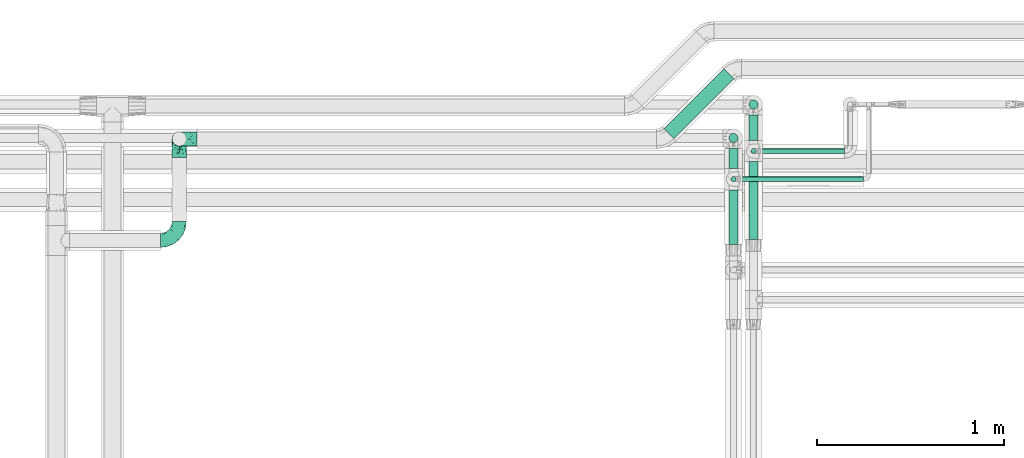
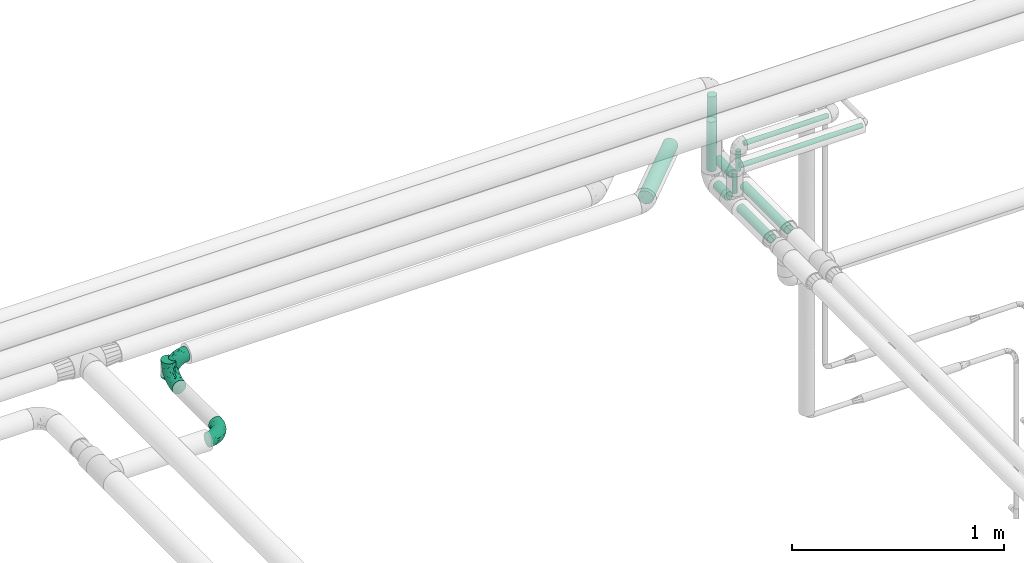
# One storey, part 654 of 827: 11 flow segments, 3 flow fittings.
"""IFC2X3 building model written with IfcOpenShell, lengths in millimetres."""

from ifc_helpers import new_model, entity, si_unit, converted_unit, derived_unit, direction, frame, origin, origin_2d_with_axis, place, context, subcontext, project, spatial, circle, extrude, faceted_brep, source, transform, mapped, material, type_object, type_shapes, element, save


model = new_model("IFC2X3")

# Units and contexts
model_context = context("Model", 3, precision=0.01, world=origin(), true_north=direction((6.12303176911189e-17, 1.0)))
body_context = subcontext(model_context, "Body", "Model", "MODEL_VIEW")
ifc_project = project(units=[si_unit("LENGTHUNIT", "METRE", prefix="MILLI"), si_unit("AREAUNIT", "SQUARE_METRE"), si_unit("VOLUMEUNIT", "CUBIC_METRE"), converted_unit("PLANEANGLEUNIT", "DEGREE", entity("IfcRatioMeasure", 0.0174532925199433), si_unit("PLANEANGLEUNIT", "RADIAN"), dimensions=[0, 0, 0, 0, 0, 0, 0]), si_unit("MASSUNIT", "GRAM", prefix="KILO"), derived_unit("MASSDENSITYUNIT", [(si_unit("MASSUNIT", "GRAM", prefix="KILO"), 1), (si_unit("LENGTHUNIT", "METRE"), -3)]), derived_unit("MOMENTOFINERTIAUNIT", [(si_unit("LENGTHUNIT", "METRE"), 4)]), si_unit("TIMEUNIT", "SECOND"), si_unit("FREQUENCYUNIT", "HERTZ"), si_unit("THERMODYNAMICTEMPERATUREUNIT", "DEGREE_CELSIUS"), derived_unit("THERMALTRANSMITTANCEUNIT", [(si_unit("MASSUNIT", "GRAM", prefix="KILO"), 1), (si_unit("THERMODYNAMICTEMPERATUREUNIT", "KELVIN"), -1), (si_unit("TIMEUNIT", "SECOND"), -3)]), derived_unit("VOLUMETRICFLOWRATEUNIT", [(si_unit("LENGTHUNIT", "METRE"), 3), (si_unit("TIMEUNIT", "SECOND"), -1)]), derived_unit("MASSFLOWRATEUNIT", [(si_unit("MASSUNIT", "GRAM", prefix="KILO"), 1), (si_unit("TIMEUNIT", "SECOND"), -1)]), derived_unit("ROTATIONALFREQUENCYUNIT", [(si_unit("TIMEUNIT", "SECOND"), -1)]), si_unit("ELECTRICCURRENTUNIT", "AMPERE"), si_unit("ELECTRICVOLTAGEUNIT", "VOLT"), si_unit("POWERUNIT", "WATT"), si_unit("FORCEUNIT", "NEWTON", prefix="KILO"), si_unit("ILLUMINANCEUNIT", "LUX"), si_unit("LUMINOUSFLUXUNIT", "LUMEN"), si_unit("LUMINOUSINTENSITYUNIT", "CANDELA"), derived_unit("USERDEFINED", [(si_unit("MASSUNIT", "GRAM", prefix="KILO"), -1), (si_unit("LENGTHUNIT", "METRE"), -2), (si_unit("TIMEUNIT", "SECOND"), 3), (si_unit("LUMINOUSFLUXUNIT", "LUMEN"), 1)]), derived_unit("LINEARVELOCITYUNIT", [(si_unit("LENGTHUNIT", "METRE"), 1), (si_unit("TIMEUNIT", "SECOND"), -1)]), si_unit("PRESSUREUNIT", "PASCAL"), derived_unit("USERDEFINED", [(si_unit("LENGTHUNIT", "METRE"), -2), (si_unit("MASSUNIT", "GRAM", prefix="KILO"), 1), (si_unit("TIMEUNIT", "SECOND"), -2)]), derived_unit("LINEARFORCEUNIT", [(si_unit("MASSUNIT", "GRAM", prefix="KILO"), 1), (si_unit("LENGTHUNIT", "METRE"), 1), (si_unit("TIMEUNIT", "SECOND"), -2), (si_unit("LENGTHUNIT", "METRE"), -1)]), derived_unit("PLANARFORCEUNIT", [(si_unit("MASSUNIT", "GRAM", prefix="KILO"), 1), (si_unit("LENGTHUNIT", "METRE"), 1), (si_unit("TIMEUNIT", "SECOND"), -2), (si_unit("LENGTHUNIT", "METRE"), -2)])], contexts=[model_context])

# Site, building, storey
site_placement = place(None, origin())
site = spatial("IfcSite", under=ifc_project, at=site_placement, CompositionType="ELEMENT")
building_placement = place(site_placement, origin())
building = spatial("IfcBuilding", under=site, at=building_placement, CompositionType="ELEMENT")
storey_placement = place(building_placement, frame((0.0, 0.0, 28200.0)))
storey = spatial("IfcBuildingStorey", under=building, at=storey_placement, Name="08", CompositionType="ELEMENT", Elevation=28200.0)

# Flow segments
pipe_segment_type = type_object("IfcPipeSegmentType", PredefinedType="NOTDEFINED")
flow_segment_1_placement = place(storey_placement, frame((40995.89, 18930.88, 2960.65)))
element("IfcFlowSegment", 1, at=flow_segment_1_placement, inside=storey, type_object=pipe_segment_type, context=body_context, shape_type="SweptSolid", body=[
    extrude(circle(Radius=37.75, at=origin_2d_with_axis()), frame((28.29, 28.29, 39.35), z_axis=(0.707106781186548, 0.707106781186548, 0.0), x_axis=(-0.707106781186548, 0.707106781186548, 0.0)), (0.0, 0.0, 1.0), 452.879995921408),
])
flow_segment_2_placement = place(storey_placement, frame((41450.62, 18393.19, 2974.4)))
element("IfcFlowSegment", 2, at=flow_segment_2_placement, inside=storey, type_object=pipe_segment_type, context=body_context, shape_type="SweptSolid", body=[
    extrude(circle(Radius=24.0, at=origin_2d_with_axis()), frame((25.6, 0.0, 25.6), z_axis=(0.0, 1.0, 0.0), x_axis=(-1.0, 0.0, 0.0)), (0.0, 0.0, 1.0), 416.031331883509),
])
flow_segment_3_placement = place(storey_placement, frame((41343.78, 18773.22, 2974.4)))
element("IfcFlowSegment", 3, at=flow_segment_3_placement, inside=storey, type_object=pipe_segment_type, context=body_context, shape_type="SweptSolid", body=[
    extrude(circle(Radius=24.0, at=origin_2d_with_axis()), frame((25.6, 0.0, 25.6), z_axis=(0.0, 1.0, 0.0), x_axis=(1.0, 0.0, 0.0)), (0.0, 0.0, 1.0), 106.243563862044),
])
flow_segment_4_placement = place(storey_placement, frame((41505.32, 18851.22, 3185.0)))
element("IfcFlowSegment", 4, at=flow_segment_4_placement, inside=storey, type_object=pipe_segment_type, context=body_context, shape_type="SweptSolid", body=[
    extrude(circle(Radius=13.4, at=origin_2d_with_axis()), frame((0.0, 15.0, 15.0), z_axis=(1.0, 0.0, 0.0), x_axis=(0.0, 1.0, 0.0)), (0.0, 0.0, 1.0), 458.985853955874),
])
flow_segment_5_placement = place(storey_placement, frame((41398.47, 18701.23, 3184.95)))
element("IfcFlowSegment", 5, at=flow_segment_5_placement, inside=storey, type_object=pipe_segment_type, context=body_context, shape_type="SweptSolid", body=[
    extrude(circle(Radius=13.4, at=origin_2d_with_axis()), frame((0.0, 15.0, 15.0), z_axis=(0.999999996394232, 0.0, 8.4920762956477e-05), x_axis=(0.0, -1.0, 0.0)), (0.0, 0.0, 1.0), 665.83210348231),
])
for number, where in (
    (6, (41343.78, 18910.87, 3057.0)),
    (7, (41450.62, 19089.89, 3057.0)),
):
    element("IfcFlowSegment", number, at=place(storey_placement, frame(where)), inside=storey, type_object=pipe_segment_type, context=body_context, shape_type="SweptSolid", body=[
        extrude(circle(Radius=24.0, at=origin_2d_with_axis()), frame((25.6, 25.6, 0.0), z_axis=(0.0, 0.0, 1.0), x_axis=(-1.0, 0.0, 0.0)), (0.0, 0.0, 1.0), 285.890661222079),
    ])
flow_segment_6_placement = place(storey_placement, frame((41461.22, 18851.22, 3057.0)))
element("IfcFlowSegment", 8, at=flow_segment_6_placement, inside=storey, type_object=pipe_segment_type, context=body_context, shape_type="SweptSolid", body=[
    extrude(circle(Radius=13.4, at=origin_2d_with_axis()), frame((15.0, 15.0, 0.0), z_axis=(0.0, 0.0, 1.0), x_axis=(-1.0, 0.0, 0.0)), (0.0, 0.0, 1.0), 113.899999999996),
])
flow_segment_7_placement = place(storey_placement, frame((41450.62, 18923.22, 2974.4)))
element("IfcFlowSegment", 9, at=flow_segment_7_placement, inside=storey, type_object=pipe_segment_type, context=body_context, shape_type="SweptSolid", body=[
    extrude(circle(Radius=24.0, at=origin_2d_with_axis()), frame((25.6, 0.0, 25.6), z_axis=(0.0, 1.0, 0.0), x_axis=(-1.0, 0.0, 0.0)), (0.0, 0.0, 1.0), 135.267782963868),
])
flow_segment_8_placement = place(storey_placement, frame((41354.38, 18701.23, 3057.0)))
element("IfcFlowSegment", 10, at=flow_segment_8_placement, inside=storey, type_object=pipe_segment_type, context=body_context, shape_type="SweptSolid", body=[
    extrude(circle(Radius=13.4, at=origin_2d_with_axis()), frame((15.0, 15.0, 0.0), z_axis=(0.0, 0.0, 1.0), x_axis=(-1.0, 0.0, 0.0)), (0.0, 0.0, 1.0), 113.840873011511),
])
flow_segment_9_placement = place(storey_placement, frame((41343.78, 18367.84, 2974.4)))
element("IfcFlowSegment", 11, at=flow_segment_9_placement, inside=storey, type_object=pipe_segment_type, context=body_context, shape_type="SweptSolid", body=[
    extrude(circle(Radius=24.0, at=origin_2d_with_axis()), frame((25.6, 0.0, 25.6), z_axis=(0.0, 1.0, 0.0), x_axis=(1.0, 0.0, 0.0)), (0.0, 0.0, 1.0), 291.378850868252),
])

# Flow fittings
ifc_material = material()
pipe_fitting_type_1 = type_object("IfcPipeFittingType", Name="ADSK_2", PredefinedType="NOTDEFINED", material=ifc_material)
shared_shape_1 = source(origin(), body_context, "Body", "Brep", [
    faceted_brep([(-100.0, 19.0, -32.91), (-100.0, 9.84, -36.71), (-100.0, 0.0, -38.0), (-100.0, -9.84, -36.71), (-100.0, -19.0, -32.91), (-100.0, -26.87, -26.87), (-100.0, -32.91, -19.0), (-100.0, -36.71, -9.84), (-100.0, -38.0, 0.0), (-100.0, -36.71, 9.84), (-100.0, -32.91, 19.0), (-100.0, -26.87, 26.87), (-100.0, -19.0, 32.91), (-100.0, -9.84, 36.71), (-100.0, 0.0, 38.0), (-100.0, 9.84, 36.71), (-100.0, 19.0, 32.91), (-100.0, 26.87, 26.87), (-100.0, 32.91, 19.0), (-100.0, 36.71, 9.84), (-100.0, 38.0, 0.0), (-100.0, 36.71, -9.84), (-100.0, 32.91, -19.0), (-100.0, 26.87, -26.87), (0.0, 100.0, -38.0), (-9.84, 100.0, -36.71), (-19.0, 100.0, -32.91), (-26.87, 100.0, -26.87), (-32.91, 100.0, -19.0), (-36.71, 100.0, -9.84), (-38.0, 100.0, 0.0), (-36.71, 100.0, 9.84), (-32.91, 100.0, 19.0), (-26.87, 100.0, 26.87), (-19.0, 100.0, 32.91), (-9.84, 100.0, 36.71), (0.0, 100.0, 38.0), (9.84, 100.0, 36.71), (19.0, 100.0, 32.91), (26.87, 100.0, 26.87), (32.91, 100.0, 19.0), (36.71, 100.0, 9.84), (38.0, 100.0, 0.0), (36.71, 100.0, -9.84), (32.91, 100.0, -19.0), (26.87, 100.0, -26.87), (19.0, 100.0, -32.91), (9.84, 100.0, -36.71), (-40.69, 71.44, 16.62), (-81.22, -35.53, 0.0), (-67.52, -31.95, 12.5), (-8.97, -2.95, 6.59), (-11.71, -2.76, 13.62), (-24.68, -14.61, 8.04), (-64.28, -33.3, 0.0), (-83.72, 23.85, 30.89), (-76.19, 33.07, 24.6), (-74.13, -28.58, 21.76), (13.92, 43.47, 26.56), (5.03, 42.28, 32.41), (2.17, 22.78, 25.61), (20.11, 65.77, 28.71), (-65.77, -20.11, 28.71), (-74.23, -13.22, 34.41), (-44.44, -24.14, 12.16), (-47.64, -26.4, 0.0), (-31.0, -19.51, 0.0), (-54.86, 48.59, 21.12), (-81.56, 37.18, 15.86), (-42.28, -5.03, 32.41), (-52.67, 2.67, 37.1), (-14.76, 85.65, 35.5), (-6.46, 75.04, 37.87), (-58.38, 40.19, 26.6), (-15.88, 37.27, 37.68), (-29.21, 13.39, 36.1), (-10.53, 30.95, 35.7), (-77.78, -4.12, 37.45), (-2.67, 52.67, 37.1), (-76.41, 41.64, 8.45), (-71.15, 7.29, 37.89), (-32.26, 79.13, 24.41), (-44.28, 53.84, 26.08), (-25.18, 76.9, 31.2), (19.6, 43.38, 19.97), (6.25, 18.29, 16.9), (19.92, 34.73, 10.46), (-60.8, 50.97, 7.63), (-76.27, 42.72, 0.0), (-77.34, 15.98, 35.72), (-15.11, 15.11, 32.27), (-22.78, -2.17, 25.61), (28.58, 74.13, 21.76), (31.95, 67.52, 12.5), (-51.02, 30.39, 34.96), (-54.69, 20.06, 37.12), (26.4, 47.64, 0.0), (-51.15, 12.85, 38.0), (-32.84, 22.95, 37.94), (4.12, 77.78, 37.45), (-43.38, -19.6, 19.97), (35.53, 81.22, 0.0), (13.22, 74.23, 34.41), (-39.82, 82.33, 7.34), (-42.72, 76.27, 0.0), (-33.83, 52.47, 33.18), (-48.09, 40.81, 31.48), (-56.16, 56.16, 0.0), (-48.2, 64.18, 8.55), (-18.69, 66.93, 35.98), (-49.98, 57.58, 16.12), (-62.54, 46.99, 14.59), (-43.26, -12.84, 27.42), (-17.52, 48.72, 37.89), (-64.19, 29.4, 31.78), (-27.05, 50.9, 36.03), (-36.14, 36.14, 36.75), (-23.99, -8.71, 19.44), (6.3, 13.34, 7.98), (19.51, 31.0, 0.0), (-7.64, 6.3, 21.15), (-16.71, -8.55, 0.0), (33.3, 64.28, 0.0), (-2.42, 2.42, 0.0), (8.55, 16.71, 0.0), (-85.65, 14.76, -35.5), (-23.85, 83.72, -30.89), (-33.07, 76.19, -24.6), (-75.04, 6.46, -37.87), (-37.27, 15.88, -37.68), (-13.39, 29.21, -36.1), (-30.95, 10.53, -35.7), (-79.13, 32.26, -24.41), (-76.9, 25.18, -31.2), (6.3, 13.34, -7.98), (-11.71, -2.76, -13.62), (6.25, 18.29, -16.9), (-82.33, 39.82, -7.34), (-66.93, 18.69, -35.98), (-48.72, 17.52, -37.89), (-64.18, 48.2, -8.55), (31.95, 67.52, -12.5), (28.58, 74.13, -21.76), (-52.47, 33.83, -33.18), (4.12, 77.78, -37.45), (-7.29, 71.15, -37.89), (-15.98, 77.34, -35.72), (-67.52, -31.95, -12.5), (-30.39, 51.02, -34.96), (-20.06, 54.69, -37.12), (-48.59, 54.86, -21.12), (-37.18, 81.56, -15.86), (-74.13, -28.58, -21.76), (-29.4, 64.19, -31.78), (-40.81, 48.09, -31.48), (-40.19, 58.38, -26.6), (-65.77, -20.11, -28.71), (-74.23, -13.22, -34.41), (-39.81, -22.62, -10.22), (-77.78, -4.12, -37.45), (-43.38, -19.6, -19.97), (-12.85, 51.15, -38.0), (-22.95, 32.84, -37.94), (-71.44, 40.69, -16.62), (19.6, 43.38, -19.97), (20.11, 65.77, -28.71), (-52.67, 2.67, -37.1), (-53.84, 44.28, -26.08), (-41.64, 76.41, -8.45), (-23.99, -8.71, -19.44), (-43.47, -13.92, -26.56), (-22.78, -2.17, -25.61), (-20.59, -12.11, -6.83), (13.22, 74.23, -34.41), (5.03, 42.28, -32.41), (-2.67, 52.67, -37.1), (19.92, 34.73, -10.46), (-42.28, -5.03, -32.41), (12.84, 43.26, -27.42), (-50.97, 60.8, -7.63), (-57.58, 49.98, -16.12), (-46.99, 62.54, -14.59), (-50.9, 27.05, -36.03), (-36.14, 36.14, -36.75), (-15.11, 15.11, -32.27), (2.17, 22.78, -25.61), (-7.64, 6.3, -21.15), (-6.28, -0.33, -7.3)], [[[0, 1, 2, 3, 4, 5, 6, 7, 8, 9, 10, 11, 12, 13, 14, 15, 16, 17, 18, 19, 20, 21, 22, 23]], [[24, 25, 26, 27, 28, 29, 30, 31, 32, 33, 34, 35, 36, 37, 38, 39, 40, 41, 42, 43, 44, 45, 46, 47]], [[32, 31, 48]], [[49, 50, 9]], [[51, 52, 53]], [[9, 50, 10]], [[54, 50, 49]], [[17, 55, 56]], [[11, 10, 57]], [[58, 59, 60]], [[61, 39, 38]], [[62, 12, 11]], [[62, 63, 12]], [[64, 65, 66]], [[56, 67, 68]], [[63, 69, 70]], [[35, 71, 72]], [[67, 56, 73]], [[74, 75, 76]], [[16, 55, 17]], [[13, 77, 14]], [[76, 78, 74]], [[68, 79, 19]], [[18, 17, 56]], [[14, 77, 80]], [[20, 19, 79]], [[81, 82, 83]], [[84, 85, 86]], [[87, 88, 79]], [[18, 68, 19]], [[15, 89, 16]], [[14, 80, 15]], [[85, 84, 60]], [[90, 69, 91]], [[92, 84, 93]], [[94, 89, 95]], [[86, 96, 93]], [[83, 71, 34]], [[95, 97, 98]], [[37, 36, 99]], [[40, 39, 92]], [[40, 93, 41]], [[66, 53, 64]], [[92, 93, 40]], [[57, 100, 62]], [[93, 101, 41]], [[93, 84, 86]], [[61, 102, 59]], [[34, 33, 83]], [[103, 48, 31]], [[50, 57, 10]], [[104, 103, 30]], [[94, 105, 106]], [[104, 107, 108]], [[12, 63, 13]], [[83, 109, 71]], [[83, 105, 109]], [[33, 81, 83]], [[67, 110, 111]], [[108, 103, 104]], [[112, 69, 62]], [[34, 71, 35]], [[36, 35, 72]], [[109, 113, 72]], [[102, 38, 37]], [[102, 61, 38]], [[114, 106, 73]], [[89, 15, 80]], [[33, 32, 81]], [[115, 105, 116]], [[109, 115, 113]], [[99, 72, 78]], [[111, 87, 79]], [[108, 87, 110]], [[69, 63, 62]], [[77, 63, 70]], [[100, 117, 112]], [[69, 90, 75]], [[99, 102, 37]], [[78, 76, 59]], [[78, 59, 102]], [[59, 90, 60]], [[100, 57, 50]], [[62, 11, 57]], [[39, 61, 92]], [[84, 92, 61]], [[95, 89, 80]], [[55, 89, 114]], [[83, 82, 105]], [[94, 106, 114]], [[98, 113, 116]], [[78, 72, 113]], [[98, 116, 95]], [[98, 70, 75]], [[32, 48, 81]], [[82, 81, 48]], [[91, 112, 117]], [[60, 84, 58]], [[113, 115, 116]], [[118, 119, 86]], [[90, 91, 60]], [[91, 117, 120]], [[72, 99, 36]], [[102, 99, 78]], [[63, 77, 13]], [[80, 77, 70]], [[95, 80, 97]], [[94, 95, 116]], [[56, 68, 18]], [[79, 68, 111]], [[110, 87, 111]], [[79, 88, 20]], [[108, 107, 87]], [[88, 87, 107]], [[120, 60, 91]], [[66, 121, 53]], [[118, 86, 85]], [[122, 93, 96]], [[52, 118, 85]], [[118, 123, 124, 119]], [[48, 103, 108]], [[30, 103, 31]], [[89, 55, 16]], [[56, 55, 114]], [[80, 70, 97]], [[70, 98, 97]], [[105, 94, 116]], [[89, 94, 114]], [[105, 82, 106]], [[73, 106, 82]], [[67, 73, 82]], [[114, 73, 56]], [[110, 82, 48]], [[67, 111, 68]], [[82, 110, 67]], [[108, 110, 48]], [[69, 75, 70]], [[76, 75, 90]], [[59, 76, 90]], [[78, 113, 74]], [[113, 98, 74]], [[75, 74, 98]], [[9, 8, 49]], [[101, 93, 122]], [[101, 42, 41]], [[72, 71, 109]], [[50, 54, 65]], [[117, 53, 52]], [[109, 105, 115]], [[100, 112, 62]], [[91, 69, 112]], [[123, 51, 121]], [[120, 52, 85]], [[52, 120, 117]], [[60, 120, 85]], [[51, 118, 52]], [[100, 64, 117]], [[50, 64, 100]], [[121, 51, 53]], [[118, 51, 123]], [[84, 61, 58]], [[59, 58, 61]], [[86, 119, 96]], [[65, 64, 50]], [[117, 64, 53]], [[125, 1, 0]], [[27, 126, 127]], [[2, 1, 128]], [[129, 130, 131]], [[132, 133, 23]], [[134, 135, 136]], [[88, 137, 20]], [[138, 139, 128]], [[88, 107, 140]], [[141, 142, 44]], [[138, 133, 143]], [[24, 144, 145]], [[146, 25, 145]], [[125, 133, 138]], [[6, 147, 7]], [[148, 146, 149]], [[147, 49, 7]], [[127, 150, 151]], [[147, 6, 152]], [[153, 154, 155]], [[156, 4, 157]], [[140, 137, 88]], [[24, 145, 25]], [[43, 42, 101]], [[65, 147, 158]], [[148, 143, 154]], [[159, 3, 2]], [[147, 152, 160]], [[149, 161, 162]], [[156, 5, 4]], [[137, 163, 21]], [[142, 164, 165]], [[131, 166, 129]], [[28, 151, 29]], [[167, 133, 132]], [[168, 30, 29]], [[169, 170, 171]], [[127, 28, 27]], [[150, 127, 155]], [[135, 172, 158]], [[26, 25, 146]], [[1, 125, 128]], [[22, 21, 163]], [[126, 27, 26]], [[151, 168, 29]], [[24, 47, 144]], [[45, 165, 46]], [[0, 23, 133]], [[173, 174, 175]], [[119, 134, 176]], [[142, 45, 44]], [[173, 46, 165]], [[141, 44, 43]], [[46, 173, 47]], [[141, 101, 122]], [[156, 157, 177]], [[157, 4, 3]], [[101, 141, 43]], [[178, 174, 165]], [[169, 160, 170]], [[6, 5, 152]], [[170, 177, 171]], [[158, 147, 160]], [[104, 168, 179]], [[141, 96, 176]], [[150, 180, 181]], [[23, 22, 132]], [[182, 143, 183]], [[138, 182, 139]], [[159, 128, 166]], [[181, 179, 168]], [[140, 179, 180]], [[159, 157, 3]], [[166, 131, 177]], [[166, 177, 157]], [[177, 184, 171]], [[174, 173, 165]], [[144, 173, 175]], [[178, 164, 185]], [[174, 184, 130]], [[5, 156, 152]], [[160, 152, 156]], [[164, 142, 141]], [[165, 45, 142]], [[149, 146, 145]], [[126, 146, 153]], [[133, 167, 143]], [[148, 154, 153]], [[162, 139, 183]], [[166, 128, 139]], [[162, 183, 149]], [[162, 175, 130]], [[22, 163, 132]], [[167, 132, 163]], [[174, 185, 184]], [[136, 176, 134]], [[185, 136, 186]], [[158, 172, 66]], [[136, 185, 164]], [[171, 184, 185]], [[128, 159, 2]], [[157, 159, 166]], [[173, 144, 47]], [[145, 144, 175]], [[149, 145, 161]], [[148, 149, 183]], [[127, 151, 28]], [[168, 151, 181]], [[180, 179, 181]], [[168, 104, 30]], [[140, 107, 179]], [[104, 179, 107]], [[176, 136, 164]], [[135, 169, 186]], [[141, 176, 164]], [[134, 119, 124, 123]], [[158, 66, 65]], [[187, 172, 135]], [[163, 137, 140]], [[20, 137, 21]], [[146, 126, 26]], [[127, 126, 153]], [[145, 175, 161]], [[175, 162, 161]], [[143, 148, 183]], [[146, 148, 153]], [[143, 167, 154]], [[155, 154, 167]], [[150, 155, 167]], [[153, 155, 127]], [[180, 167, 163]], [[150, 181, 151]], [[167, 180, 150]], [[140, 180, 163]], [[174, 130, 175]], [[131, 130, 184]], [[177, 131, 184]], [[166, 139, 129]], [[139, 162, 129]], [[130, 129, 162]], [[49, 147, 54]], [[49, 8, 7]], [[133, 125, 0]], [[128, 125, 138]], [[158, 160, 169]], [[65, 54, 147]], [[187, 135, 134]], [[187, 121, 172]], [[134, 123, 187]], [[139, 182, 183]], [[121, 187, 123]], [[121, 66, 172]], [[138, 143, 182]], [[160, 156, 170]], [[177, 170, 156]], [[186, 169, 171]], [[158, 169, 135]], [[185, 186, 171]], [[135, 186, 136]], [[164, 178, 165]], [[185, 174, 178]], [[96, 141, 122]], [[96, 119, 176]]]),
])
type_shapes(pipe_fitting_type_1, [shared_shape_1])
flow_fitting_1_placement = place(storey_placement, frame((38405.22, 18388.39, 2900.08)))
element("IfcFlowFitting", 12, at=flow_fitting_1_placement, inside=storey, type_object=pipe_fitting_type_1, material=ifc_material, Name="ADSK_2", ObjectType="ADSK_2", context=body_context, shape_type="MappedRepresentation", body=[
    mapped(shared_shape_1, transform((0.0, 0.0, 0.0), scale=1.0)),
])
flow_fitting_2_placement = place(storey_placement, frame((38405.22, 18931.35, 2900.08), z_axis=(1.0, 0.0, 0.0), x_axis=(0.0, 1.0, 0.0)))
element("IfcFlowFitting", 13, at=flow_fitting_2_placement, inside=storey, type_object=pipe_fitting_type_1, material=ifc_material, Name="ADSK_2", ObjectType="ADSK_2", context=body_context, shape_type="MappedRepresentation", body=[
    mapped(shared_shape_1, transform((0.0, 0.0, 0.0), scale=1.0)),
])
pipe_fitting_type_2 = type_object("IfcPipeFittingType", Name="ADSK_1", PredefinedType="NOTDEFINED", material=ifc_material)
shared_shape_2 = source(origin(), body_context, "Body", "Brep", [
    faceted_brep([(-95.0, 19.02, -32.95), (-95.0, 9.85, -36.75), (-95.0, 0.0, -38.05), (-95.0, -9.85, -36.75), (-95.0, -19.03, -32.95), (-95.0, -26.91, -26.91), (-95.0, -32.95, -19.03), (-95.0, -36.75, -9.85), (-95.0, -38.05, 0.0), (-95.0, -36.75, 9.85), (-95.0, -32.95, 19.02), (-95.0, -26.91, 26.91), (-95.0, -19.03, 32.95), (-95.0, -9.85, 36.75), (-95.0, 0.0, 38.05), (-95.0, 9.85, 36.75), (-95.0, 19.02, 32.95), (-95.0, 26.91, 26.91), (-95.0, 32.95, 19.02), (-95.0, 36.75, 9.85), (-95.0, 38.05, 0.0), (-95.0, 36.75, -9.85), (-95.0, 32.95, -19.03), (-95.0, 26.91, -26.91), (0.0, 95.0, -38.05), (-9.85, 95.0, -36.75), (-19.02, 95.0, -32.95), (-26.91, 95.0, -26.91), (-32.95, 95.0, -19.03), (-36.75, 95.0, -9.85), (-38.05, 95.0, 0.0), (-36.75, 95.0, 9.85), (-32.95, 95.0, 19.02), (-26.91, 95.0, 26.91), (-19.02, 95.0, 32.95), (-9.85, 95.0, 36.75), (0.0, 95.0, 38.05), (9.85, 95.0, 36.75), (19.03, 95.0, 32.95), (26.91, 95.0, 26.91), (32.95, 95.0, 19.02), (36.75, 95.0, 9.85), (38.05, 95.0, 0.0), (36.75, 95.0, -9.85), (32.95, 95.0, -19.03), (26.91, 95.0, -26.91), (19.03, 95.0, -32.95), (9.85, 95.0, -36.75), (-7.99, -4.96, 6.3), (-0.92, 0.92, 0.0), (4.62, 8.1, 8.01), (-76.19, -35.57, 0.0), (-64.32, -32.32, 12.43), (20.51, 62.45, 28.68), (-60.56, -33.52, 0.0), (-70.4, -13.47, 34.42), (-39.61, -5.88, 32.32), (-49.6, 2.07, 37.1), (-70.34, -28.81, 21.71), (14.64, 40.81, 26.5), (5.88, 39.61, 32.32), (3.59, 20.77, 25.31), (-40.45, 68.06, 16.75), (-62.45, -20.51, 28.68), (-44.52, -26.87, 0.0), (-28.47, -20.22, 0.0), (-26.43, -17.83, 8.75), (-76.1, 39.63, 10.76), (-72.74, 37.58, 18.19), (-60.35, 46.18, 14.61), (-13.4, 13.4, 32.12), (-20.77, -3.59, 25.31), (-14.66, 81.47, 35.56), (-6.22, 71.26, 37.92), (-57.5, 42.48, 22.79), (-15.0, 34.74, 37.7), (-27.1, 12.08, 36.05), (-9.2, 28.81, 35.63), (-79.98, 23.7, 30.95), (-73.68, -4.3, 37.48), (-30.74, 21.67, 37.97), (-62.36, 47.59, 6.79), (-72.71, 32.83, 24.69), (-67.42, 7.02, 37.95), (-32.13, 75.27, 24.51), (-43.46, 51.47, 26.26), (-24.98, 73.15, 31.29), (20.59, 41.28, 19.85), (7.79, 16.09, 15.86), (-73.21, 42.39, 0.0), (-54.73, 54.73, 0.0), (-73.44, 15.79, 35.79), (-5.94, 4.32, 20.43), (28.81, 70.34, 21.71), (32.32, 64.32, 12.43), (-53.59, 26.2, 35.09), (-52.02, 19.31, 37.21), (21.38, 33.53, 10.34), (26.87, 44.52, 0.0), (-48.28, 12.14, 38.05), (4.3, 73.68, 37.48), (-44.08, -25.52, 12.79), (-41.28, -20.59, 19.85), (35.57, 76.19, 0.0), (-47.26, 54.3, 20.18), (-47.4, 61.99, 8.58), (-42.39, 73.21, 0.0), (-39.67, 78.86, 7.21), (-45.69, 36.84, 33.11), (-32.83, 50.13, 33.35), (13.47, 70.4, 34.42), (-18.25, 63.73, 36.07), (-40.63, -13.75, 27.22), (-16.63, 46.37, 37.95), (-53.47, 38.79, 28.59), (-26.07, 48.54, 36.15), (-34.51, 34.51, 36.86), (-2.07, 49.6, 37.1), (-22.79, -10.49, 19.23), (-61.73, 28.67, 31.87), (9.65, 14.7, 0.0), (20.22, 28.47, 0.0), (33.52, 60.56, 0.0), (-11.42, -5.44, 13.25), (-14.7, -9.65, 0.0), (-81.47, 14.66, -35.56), (-62.45, -20.51, -28.68), (-71.26, 6.22, -37.92), (-75.27, 32.13, -24.51), (-73.15, 24.98, -31.29), (13.47, 70.4, -34.42), (5.88, 39.61, -32.32), (-2.07, 49.6, -37.1), (-78.86, 39.67, -7.21), (-70.4, -13.47, -34.42), (-39.61, -5.88, -32.32), (-61.99, 47.4, -8.58), (32.32, 64.32, -12.43), (28.81, 70.34, -21.71), (-63.73, 18.25, -36.07), (-50.13, 32.83, -33.35), (4.3, 73.68, -37.48), (-7.02, 67.42, -37.95), (-39.63, 76.1, -10.76), (-46.18, 60.35, -14.61), (-47.59, 62.36, -6.79), (-64.32, -32.32, -12.43), (-26.2, 53.59, -35.09), (-15.79, 73.44, -35.79), (-19.31, 52.02, -37.21), (-37.58, 72.74, -18.19), (-70.34, -28.81, -21.71), (-42.48, 57.5, -22.79), (-38.79, 53.47, -28.59), (-51.47, 43.46, -26.26), (-32.83, 72.71, -24.69), (-46.37, 16.63, -37.95), (-73.68, -4.3, -37.48), (-41.28, -20.59, -19.85), (-44.08, -25.52, -12.79), (13.75, 40.63, -27.22), (20.51, 62.45, -28.68), (-68.06, 40.45, -16.75), (-54.3, 47.26, -20.18), (-12.14, 48.28, -38.05), (-21.67, 30.74, -37.97), (-36.84, 45.69, -33.11), (-11.42, -5.44, -13.25), (7.79, 16.09, -15.86), (4.62, 8.1, -8.01), (-23.7, 79.98, -30.95), (-26.43, -17.83, -8.75), (-7.99, -4.96, -6.3), (-40.81, -14.64, -26.5), (-20.77, -3.59, -25.31), (-34.74, 15.0, -37.7), (-12.08, 27.1, -36.05), (-28.81, 9.2, -35.63), (-22.79, -10.49, -19.23), (21.38, 33.53, -10.34), (20.59, 41.28, -19.85), (-48.54, 26.07, -36.15), (-49.6, 2.07, -37.1), (-13.4, 13.4, -32.12), (3.59, 20.77, -25.31), (-28.67, 61.73, -31.87), (-34.51, 34.51, -36.86), (-5.94, 4.32, -20.43)], [[[0, 1, 2, 3, 4, 5, 6, 7, 8, 9, 10, 11, 12, 13, 14, 15, 16, 17, 18, 19, 20, 21, 22, 23]], [[24, 25, 26, 27, 28, 29, 30, 31, 32, 33, 34, 35, 36, 37, 38, 39, 40, 41, 42, 43, 44, 45, 46, 47]], [[48, 49, 50]], [[51, 52, 9]], [[53, 39, 38]], [[9, 52, 10]], [[54, 52, 51]], [[55, 56, 57]], [[11, 10, 58]], [[59, 60, 61]], [[32, 31, 62]], [[63, 12, 11]], [[63, 55, 12]], [[64, 65, 66]], [[67, 68, 69]], [[70, 56, 71]], [[35, 72, 73]], [[69, 68, 74]], [[75, 76, 77]], [[16, 78, 17]], [[13, 79, 14]], [[76, 75, 80]], [[67, 69, 81]], [[18, 17, 82]], [[14, 79, 83]], [[20, 19, 67]], [[84, 85, 86]], [[87, 61, 88]], [[89, 81, 90]], [[18, 82, 68]], [[15, 91, 16]], [[14, 83, 15]], [[71, 92, 61]], [[17, 78, 82]], [[93, 87, 94]], [[95, 91, 96]], [[97, 98, 94]], [[86, 72, 34]], [[96, 99, 80]], [[37, 36, 100]], [[40, 39, 93]], [[40, 94, 41]], [[64, 66, 101]], [[93, 94, 40]], [[58, 102, 63]], [[94, 103, 41]], [[94, 87, 97]], [[104, 69, 74]], [[34, 33, 86]], [[105, 69, 104]], [[52, 58, 10]], [[106, 107, 30]], [[108, 109, 85]], [[105, 106, 90]], [[53, 110, 60]], [[86, 111, 72]], [[86, 109, 111]], [[33, 84, 86]], [[12, 55, 13]], [[112, 56, 63]], [[110, 38, 37]], [[34, 72, 35]], [[36, 35, 73]], [[111, 113, 73]], [[105, 107, 106]], [[110, 53, 38]], [[74, 114, 85]], [[91, 15, 83]], [[105, 90, 81]], [[107, 62, 31]], [[33, 32, 84]], [[115, 109, 116]], [[111, 115, 113]], [[100, 73, 117]], [[56, 55, 63]], [[79, 55, 57]], [[102, 118, 112]], [[56, 70, 76]], [[100, 110, 37]], [[117, 77, 60]], [[117, 60, 110]], [[60, 70, 61]], [[58, 52, 101]], [[63, 11, 58]], [[39, 53, 93]], [[87, 93, 53]], [[96, 91, 83]], [[78, 91, 119]], [[32, 62, 84]], [[84, 62, 104]], [[86, 85, 109]], [[85, 114, 108]], [[80, 113, 116]], [[117, 73, 113]], [[80, 116, 96]], [[80, 57, 76]], [[71, 112, 118]], [[61, 87, 59]], [[62, 107, 105]], [[97, 120, 121]], [[70, 71, 61]], [[71, 118, 92]], [[73, 100, 36]], [[110, 100, 117]], [[55, 79, 13]], [[83, 79, 57]], [[96, 83, 99]], [[116, 108, 95]], [[50, 97, 88]], [[97, 87, 88]], [[50, 49, 120]], [[122, 94, 98]], [[89, 20, 67]], [[105, 81, 69]], [[89, 67, 81]], [[68, 19, 18]], [[68, 67, 19]], [[74, 68, 82]], [[114, 82, 119]], [[74, 85, 104]], [[82, 114, 74]], [[114, 119, 108]], [[95, 108, 119]], [[116, 109, 108]], [[123, 48, 50]], [[97, 50, 120]], [[123, 50, 88]], [[91, 95, 119]], [[116, 95, 96]], [[84, 104, 85]], [[104, 62, 105]], [[83, 57, 99]], [[57, 80, 99]], [[66, 48, 123]], [[66, 124, 48]], [[118, 66, 123]], [[124, 66, 65]], [[66, 118, 101]], [[54, 64, 52]], [[124, 49, 48]], [[30, 107, 31]], [[91, 78, 16]], [[82, 78, 119]], [[56, 76, 57]], [[77, 76, 70]], [[60, 77, 70]], [[77, 117, 75]], [[117, 113, 75]], [[113, 80, 75]], [[9, 8, 51]], [[103, 94, 122]], [[103, 42, 41]], [[73, 72, 111]], [[113, 115, 116]], [[111, 109, 115]], [[102, 112, 63]], [[71, 56, 112]], [[118, 102, 101]], [[92, 123, 88]], [[123, 92, 118]], [[61, 92, 88]], [[87, 53, 59]], [[60, 59, 53]], [[97, 121, 98]], [[58, 101, 102]], [[64, 101, 52]], [[125, 1, 0]], [[126, 5, 4]], [[2, 1, 127]], [[1, 125, 127]], [[128, 129, 23]], [[130, 131, 132]], [[89, 133, 20]], [[126, 134, 135]], [[136, 89, 90]], [[137, 138, 44]], [[139, 129, 140]], [[24, 141, 142]], [[143, 144, 145]], [[125, 129, 139]], [[6, 146, 7]], [[147, 148, 149]], [[146, 51, 7]], [[143, 150, 144]], [[146, 6, 151]], [[152, 153, 154]], [[126, 4, 134]], [[0, 23, 129]], [[28, 155, 150]], [[43, 42, 103]], [[54, 146, 64]], [[139, 156, 127]], [[157, 3, 2]], [[151, 158, 159]], [[160, 131, 161]], [[22, 21, 162]], [[136, 144, 163]], [[149, 164, 165]], [[24, 142, 25]], [[166, 140, 154]], [[154, 129, 128]], [[143, 30, 29]], [[167, 168, 169]], [[155, 28, 27]], [[26, 170, 27]], [[171, 167, 172]], [[26, 25, 148]], [[27, 170, 155]], [[173, 135, 174]], [[144, 150, 152]], [[175, 176, 177]], [[24, 47, 141]], [[45, 161, 46]], [[148, 25, 142]], [[176, 175, 165]], [[64, 159, 171]], [[138, 45, 44]], [[130, 46, 161]], [[137, 44, 43]], [[178, 159, 158]], [[137, 103, 122]], [[163, 144, 152]], [[136, 133, 89]], [[103, 137, 43]], [[6, 5, 151]], [[178, 158, 173]], [[134, 4, 3]], [[178, 173, 174]], [[137, 98, 179]], [[145, 90, 106]], [[138, 180, 161]], [[46, 130, 47]], [[136, 90, 145]], [[133, 162, 21]], [[23, 22, 128]], [[139, 140, 181]], [[139, 181, 156]], [[157, 127, 182]], [[157, 134, 3]], [[182, 177, 135]], [[182, 135, 134]], [[135, 183, 174]], [[131, 130, 161]], [[141, 130, 132]], [[160, 180, 184]], [[131, 183, 176]], [[5, 126, 151]], [[158, 151, 126]], [[180, 138, 137]], [[161, 45, 138]], [[149, 148, 142]], [[170, 148, 185]], [[22, 162, 128]], [[128, 162, 163]], [[129, 154, 140]], [[154, 153, 166]], [[165, 156, 186]], [[182, 127, 156]], [[165, 186, 149]], [[165, 132, 176]], [[131, 184, 183]], [[187, 167, 178]], [[184, 168, 187]], [[167, 169, 172]], [[184, 180, 168]], [[174, 183, 184]], [[127, 157, 2]], [[134, 157, 182]], [[130, 141, 47]], [[142, 141, 132]], [[149, 142, 164]], [[186, 166, 147]], [[180, 179, 168]], [[169, 179, 120]], [[137, 179, 180]], [[179, 121, 120]], [[106, 30, 143]], [[136, 145, 144]], [[106, 143, 145]], [[150, 29, 28]], [[150, 143, 29]], [[152, 150, 155]], [[153, 155, 185]], [[152, 154, 163]], [[155, 153, 152]], [[153, 185, 166]], [[147, 166, 185]], [[186, 140, 166]], [[169, 120, 49]], [[169, 49, 172]], [[179, 169, 168]], [[148, 147, 185]], [[186, 147, 149]], [[128, 163, 154]], [[163, 162, 136]], [[142, 132, 164]], [[132, 165, 164]], [[171, 124, 65]], [[124, 171, 172]], [[64, 146, 159]], [[171, 159, 178]], [[171, 65, 64]], [[172, 49, 124]], [[162, 133, 136]], [[20, 133, 21]], [[148, 170, 26]], [[155, 170, 185]], [[131, 176, 132]], [[177, 176, 183]], [[135, 177, 183]], [[177, 182, 175]], [[182, 156, 175]], [[156, 165, 175]], [[51, 146, 54]], [[51, 8, 7]], [[129, 125, 0]], [[127, 125, 139]], [[140, 186, 181]], [[156, 181, 186]], [[158, 126, 173]], [[135, 173, 126]], [[187, 178, 174]], [[171, 178, 167]], [[184, 187, 174]], [[167, 187, 168]], [[180, 160, 161]], [[184, 131, 160]], [[98, 137, 122]], [[98, 121, 179]], [[151, 159, 146]]]),
])
type_shapes(pipe_fitting_type_2, [shared_shape_2])
flow_fitting_3_placement = place(storey_placement, frame((38405.22, 18931.35, 3000.0), z_axis=(0.0, 1.0, 0.0), x_axis=(0.0, 0.0, 1.0)))
element("IfcFlowFitting", 14, at=flow_fitting_3_placement, inside=storey, type_object=pipe_fitting_type_2, material=ifc_material, Name="ADSK_1", ObjectType="ADSK_1", context=body_context, shape_type="MappedRepresentation", body=[
    mapped(shared_shape_2, transform((0.0, 0.0, 0.0), scale=1.0)),
])

save(model, "model.ifc")
